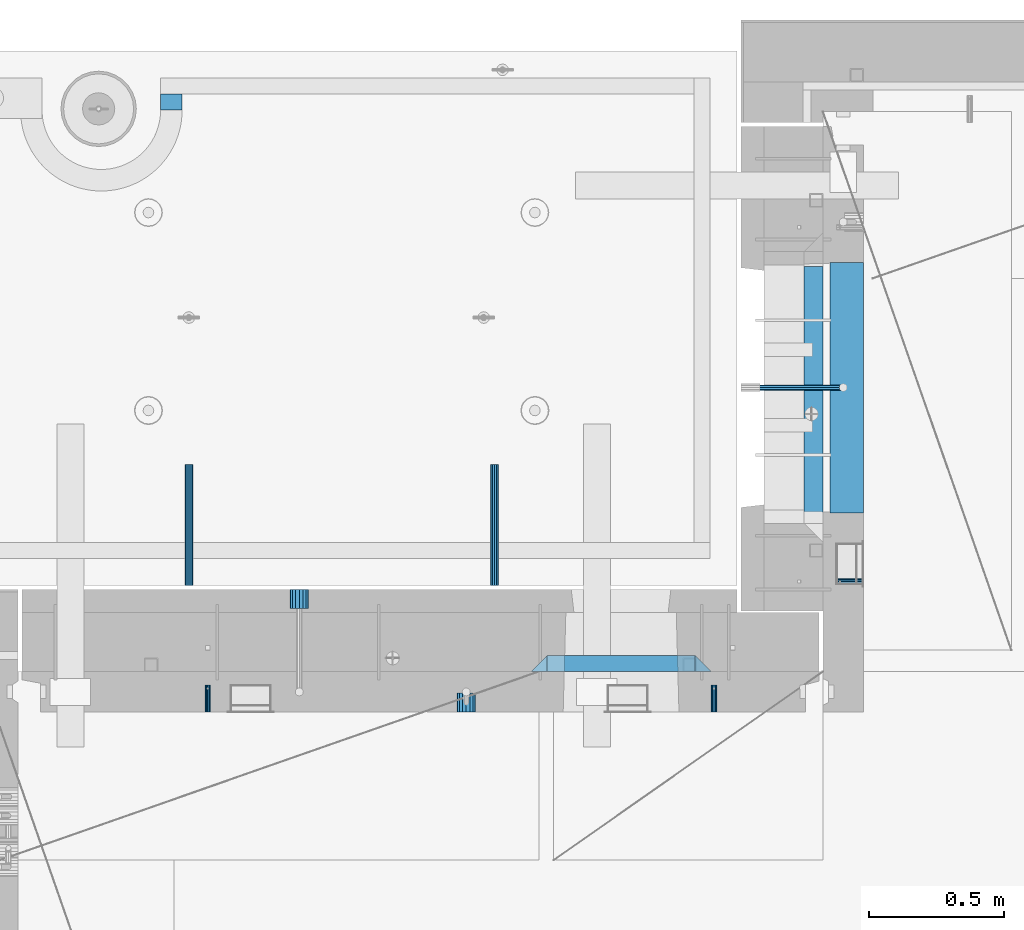
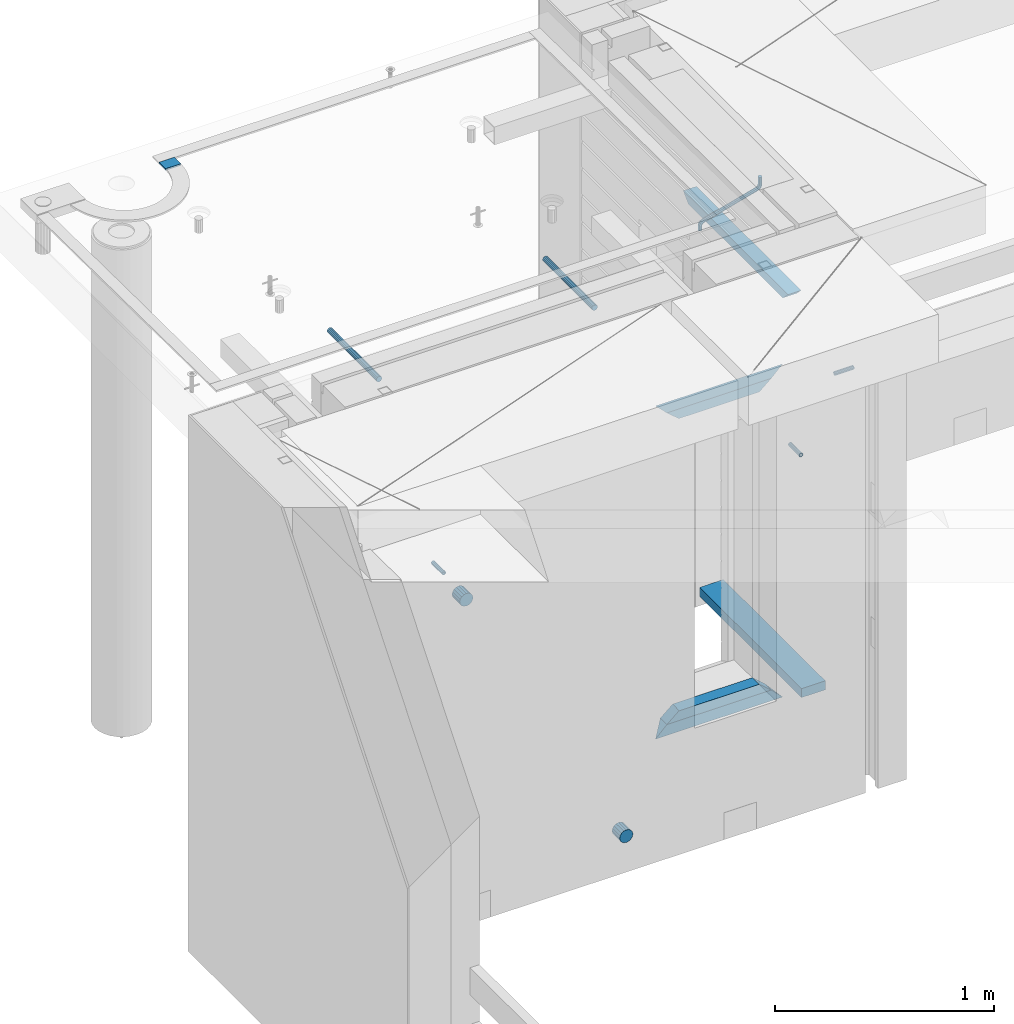
# One storey, part 150 of 334: 15 beams, 8 elements without a shape of their own.
"""IFC2X3 building model written with IfcOpenShell, lengths in millimetres."""

from ifc_helpers import new_model, si_unit, frame, origin_with_axes, place, context, subcontext, project, spatial, faceted_brep, material, type_object, element, aggregate, save


model = new_model("IFC2X3")

# Units and contexts
model_context = context("Model", 3, precision=1e-05, world=origin_with_axes())
body_context = subcontext(model_context, "Body", "Model", "MODEL_VIEW")
ifc_project = project(units=[si_unit("LENGTHUNIT", "METRE", prefix="MILLI"), si_unit("AREAUNIT", "SQUARE_METRE"), si_unit("VOLUMEUNIT", "CUBIC_METRE"), si_unit("MASSUNIT", "GRAM", prefix="KILO"), si_unit("TIMEUNIT", "SECOND"), si_unit("PLANEANGLEUNIT", "RADIAN"), si_unit("SOLIDANGLEUNIT", "STERADIAN"), si_unit("THERMODYNAMICTEMPERATUREUNIT", "DEGREE_CELSIUS"), si_unit("LUMINOUSINTENSITYUNIT", "LUMEN")], contexts=[model_context])

# Site, building, storey
site_placement = place(None, origin_with_axes())
site = spatial("IfcSite", under=ifc_project, at=site_placement, CompositionType="ELEMENT")
building_placement = place(site_placement, origin_with_axes())
building = spatial("IfcBuilding", under=site, at=building_placement, CompositionType="ELEMENT")
storey_placement = place(building_placement, origin_with_axes())
storey = spatial("IfcBuildingStorey", under=building, at=storey_placement, Name="3", CompositionType="ELEMENT", Elevation=0.0)

# Assembly, beam
assembly_1_placement = place(storey_placement, origin_with_axes())
assembly_1 = element("IfcElementAssembly", 1, at=assembly_1_placement, inside=storey, AssemblyPlace="NOTDEFINED", PredefinedType="REINFORCEMENT_UNIT")
ifc_material_1 = material(Name="CONCRETE/C25/30")
beam_type_1 = type_object("IfcBeamType", PredefinedType="NOTDEFINED")
beam_1_placement = place(assembly_1_placement, frame((10955.0, 22139.9998901814, 90080.0), z_axis=(0.0, 0.0, -1.0), x_axis=(0.0, -1.0, 0.0)))
beam_1 = element("IfcBeam", 2, at=beam_1_placement, type_object=beam_type_1, material=ifc_material_1, Name="SK", context=body_context, shape_type="Brep", body=[
    faceted_brep([(100.641025641038, 35.0, 20.6410256410309), (55.0, 35.0, -25.0), (55.0, -35.0, -25.0), (98.8461538461561, -35.0, 18.8461538461561), (966.153464684117, -35.0, 18.8461538461561), (964.358592889246, 35.0, 20.6410256410309), (1009.99961853027, 35.0, -25.0), (1009.99961853027, -35.0, -25.0)], [[[0, 1, 2, 3]], [[0, 3, 4, 5]], [[1, 0, 5, 6]], [[2, 1, 6, 7]], [[3, 2, 7, 4]], [[4, 7, 6, 5]]]),
])

# Assemblies, beams
assembly_2_placement = place(storey_placement, origin_with_axes())
assembly_2 = element("IfcElementAssembly", 3, at=assembly_2_placement, inside=storey, AssemblyPlace="NOTDEFINED", PredefinedType="REINFORCEMENT_UNIT")
assembly_3_placement = place(assembly_2_placement, origin_with_axes())
assembly_3 = element("IfcElementAssembly", 4, at=assembly_3_placement, Name="Steel Assembly", AssemblyPlace="NOTDEFINED", PredefinedType="RIGID_FRAME")
ifc_material_2 = material(Name="STEEL/Steel_Undefined")
beam_type_2 = type_object("IfcBeamType", PredefinedType="NOTDEFINED")
beam_2_placement = place(assembly_3_placement, frame((8704.99903261663, 20429.9951872276, 89755.0), z_axis=(1.0, 0.0, 0.0), x_axis=(0.0, 1.0, 0.0)))
beam_2 = element("IfcBeam", 5, at=beam_2_placement, type_object=beam_type_2, material=ifc_material_2, Name="M16", context=body_context, shape_type="Brep", body=[
    faceted_brep([(0.0, -8.49999999999272, -1.45519152283669e-11), (0.0, -7.36121593215648, 4.24999999998545), (100.000000000262, -7.36121593215648, 4.24999999998545), (100.000000000262, -8.49999999999272, -1.45519152283669e-11), (0.0, -4.24999999998545, 7.36121593216376), (100.000000000262, -4.24999999998545, 7.36121593216376), (0.0, 1.45519152283669e-11, 8.49999999998545), (100.000000000262, 1.45519152283669e-11, 8.49999999998545), (0.0, 4.25000000001455, 7.36121593216376), (100.000000000262, 4.25000000001455, 7.36121593216376), (0.0, 7.36121593217104, 4.24999999998545), (100.000000000262, 7.36121593217104, 4.24999999998545), (0.0, 8.50000000000728, 0.0), (100.000000000262, 8.50000000000728, 0.0), (0.0, 7.36121593217104, -4.25000000001455), (100.000000000262, 7.36121593217104, -4.25000000001455), (0.0, 4.25000000000728, -7.36121593219286), (100.000000000262, 4.25000000000728, -7.36121593219286), (0.0, 7.27595761418343e-12, -8.5), (100.000000000262, 7.27595761418343e-12, -8.5), (0.0, -4.24999999999272, -7.36121593217831), (100.000000000262, -4.24999999999272, -7.36121593217831), (0.0, -7.36121593215648, -4.25), (100.000000000262, -7.36121593215648, -4.25), (0.0, -10.4999999999927, -1.45519152283669e-11), (0.0, -9.09326673972828, -5.25000000001455), (100.000000000262, -9.09326673972828, -5.25000000001455), (100.000000000262, -10.4999999999927, -1.45519152283669e-11), (0.0, -5.24999999998545, -9.09326673974283), (100.000000000262, -5.24999999998545, -9.09326673974283), (0.0, 7.27595761418343e-12, -10.5), (100.000000000262, 7.27595761418343e-12, -10.5), (0.0, 5.25000000001455, -9.09326673975738), (100.000000000262, 5.25000000001455, -9.09326673975738), (0.0, 9.09326673975011, -5.25000000001455), (100.000000000262, 9.09326673975011, -5.25000000001455), (0.0, 10.5000000000073, -1.45519152283669e-11), (100.000000000262, 10.5000000000073, -1.45519152283669e-11), (0.0, 9.09326673975011, 5.25), (100.000000000262, 9.09326673975011, 5.25), (0.0, 5.25000000000728, 9.09326673972828), (100.000000000262, 5.25000000000728, 9.09326673972828), (0.0, 1.45519152283669e-11, 10.4999999999854), (100.000000000262, 1.45519152283669e-11, 10.4999999999854), (0.0, -5.24999999999272, 9.09326673972828), (100.000000000262, -5.24999999999272, 9.09326673972828), (0.0, -9.09326673972828, 5.24999999998545), (100.000000000262, -9.09326673972828, 5.24999999998545)], [[[0, 1, 2, 3]], [[1, 4, 5, 2]], [[4, 6, 7, 5]], [[6, 8, 9, 7]], [[8, 10, 11, 9]], [[10, 12, 13, 11]], [[12, 14, 15, 13]], [[14, 16, 17, 15]], [[16, 18, 19, 17]], [[18, 20, 21, 19]], [[20, 22, 23, 21]], [[22, 0, 3, 23]], [[24, 25, 26, 27]], [[25, 28, 29, 26]], [[28, 30, 31, 29]], [[30, 32, 33, 31]], [[32, 34, 35, 33]], [[34, 36, 37, 35]], [[36, 38, 39, 37]], [[38, 40, 41, 39]], [[40, 42, 43, 41]], [[42, 44, 45, 43]], [[44, 46, 47, 45]], [[46, 24, 27, 47]], [[29, 31, 33, 35, 37, 39, 41, 43, 45, 47, 27, 26], [5, 7, 9, 11, 13, 15, 17, 19, 21, 23, 3, 2]], [[46, 44, 42, 40, 38, 36, 34, 32, 30, 28, 25, 24], [22, 20, 18, 16, 14, 12, 10, 8, 6, 4, 1, 0]]]),
])
aggregate(assembly_3, [beam_2])
assembly_4_placement = place(assembly_2_placement, origin_with_axes())
assembly_4 = element("IfcElementAssembly", 6, at=assembly_4_placement, Name="Steel Assembly", AssemblyPlace="NOTDEFINED", PredefinedType="RIGID_FRAME")
beam_3_placement = place(assembly_4_placement, frame((10584.9990326166, 20429.9951872276, 89755.0), z_axis=(1.0, 0.0, 0.0), x_axis=(0.0, 1.0, 0.0)))
beam_3 = element("IfcBeam", 7, at=beam_3_placement, type_object=beam_type_2, material=ifc_material_2, Name="M16", context=body_context, shape_type="Brep", body=[
    faceted_brep([(0.0, -8.49999999999272, -1.45519152283669e-11), (0.0, -7.36121593215648, 4.24999999998545), (100.000000000262, -7.36121593215648, 4.24999999998545), (100.000000000262, -8.49999999999272, -1.45519152283669e-11), (0.0, -4.24999999998545, 7.36121593216376), (100.000000000262, -4.24999999998545, 7.36121593216376), (0.0, 1.45519152283669e-11, 8.49999999998545), (100.000000000262, 1.45519152283669e-11, 8.49999999998545), (0.0, 4.25000000001455, 7.36121593216376), (100.000000000262, 4.25000000001455, 7.36121593216376), (0.0, 7.36121593217104, 4.24999999998545), (100.000000000262, 7.36121593217104, 4.24999999998545), (0.0, 8.50000000000728, 0.0), (100.000000000262, 8.50000000000728, 0.0), (0.0, 7.36121593217104, -4.25000000001455), (100.000000000262, 7.36121593217104, -4.25000000001455), (0.0, 4.25000000000728, -7.36121593219286), (100.000000000262, 4.25000000000728, -7.36121593219286), (0.0, 7.27595761418343e-12, -8.5), (100.000000000262, 7.27595761418343e-12, -8.5), (0.0, -4.24999999999272, -7.36121593217831), (100.000000000262, -4.24999999999272, -7.36121593217831), (0.0, -7.36121593215648, -4.25), (100.000000000262, -7.36121593215648, -4.25), (0.0, -10.4999999999927, -1.45519152283669e-11), (0.0, -9.09326673972828, -5.25000000001455), (100.000000000262, -9.09326673972828, -5.25000000001455), (100.000000000262, -10.4999999999927, -1.45519152283669e-11), (0.0, -5.24999999998545, -9.09326673974283), (100.000000000262, -5.24999999998545, -9.09326673974283), (0.0, 7.27595761418343e-12, -10.5), (100.000000000262, 7.27595761418343e-12, -10.5), (0.0, 5.25000000001455, -9.09326673975738), (100.000000000262, 5.25000000001455, -9.09326673975738), (0.0, 9.09326673975011, -5.25000000001455), (100.000000000262, 9.09326673975011, -5.25000000001455), (0.0, 10.5000000000073, -1.45519152283669e-11), (100.000000000262, 10.5000000000073, -1.45519152283669e-11), (0.0, 9.09326673975011, 5.25), (100.000000000262, 9.09326673975011, 5.25), (0.0, 5.25000000000728, 9.09326673972828), (100.000000000262, 5.25000000000728, 9.09326673972828), (0.0, 1.45519152283669e-11, 10.4999999999854), (100.000000000262, 1.45519152283669e-11, 10.4999999999854), (0.0, -5.24999999999272, 9.09326673972828), (100.000000000262, -5.24999999999272, 9.09326673972828), (0.0, -9.09326673972828, 5.24999999998545), (100.000000000262, -9.09326673972828, 5.24999999998545)], [[[0, 1, 2, 3]], [[1, 4, 5, 2]], [[4, 6, 7, 5]], [[6, 8, 9, 7]], [[8, 10, 11, 9]], [[10, 12, 13, 11]], [[12, 14, 15, 13]], [[14, 16, 17, 15]], [[16, 18, 19, 17]], [[18, 20, 21, 19]], [[20, 22, 23, 21]], [[22, 0, 3, 23]], [[24, 25, 26, 27]], [[25, 28, 29, 26]], [[28, 30, 31, 29]], [[30, 32, 33, 31]], [[32, 34, 35, 33]], [[34, 36, 37, 35]], [[36, 38, 39, 37]], [[38, 40, 41, 39]], [[40, 42, 43, 41]], [[42, 44, 45, 43]], [[44, 46, 47, 45]], [[46, 24, 27, 47]], [[29, 31, 33, 35, 37, 39, 41, 43, 45, 47, 27, 26], [5, 7, 9, 11, 13, 15, 17, 19, 21, 23, 3, 2]], [[46, 44, 42, 40, 38, 36, 34, 32, 30, 28, 25, 24], [22, 20, 18, 16, 14, 12, 10, 8, 6, 4, 1, 0]]]),
])
aggregate(assembly_4, [beam_3])

# Assembly, beam
assembly_5_placement = place(assembly_1_placement, origin_with_axes())
assembly_5 = element("IfcElementAssembly", 8, at=assembly_5_placement, Name="Steel Assembly", AssemblyPlace="NOTDEFINED", PredefinedType="RIGID_FRAME")
beam_4_placement = place(assembly_5_placement, frame((11140.0, 20914.9954408996, 89755.0), z_axis=(0.0, -1.0, 0.0), x_axis=(-1.0, 3.00000001838171e-08, 0.0)))
beam_4 = element("IfcBeam", 9, at=beam_4_placement, type_object=beam_type_2, material=ifc_material_2, Name="M16", context=body_context, shape_type="Brep", body=[
    faceted_brep([(0.0, -8.49999999999272, -1.45519152283669e-11), (0.0, -7.36121593215648, 4.24999999998545), (100.000000000262, -7.36121593215648, 4.24999999998545), (100.000000000262, -8.49999999999272, -1.45519152283669e-11), (0.0, -4.24999999998545, 7.36121593216376), (100.000000000262, -4.24999999998545, 7.36121593216376), (0.0, 1.45519152283669e-11, 8.49999999998545), (100.000000000262, 1.45519152283669e-11, 8.49999999998545), (0.0, 4.25000000001455, 7.36121593216376), (100.000000000262, 4.25000000001455, 7.36121593216376), (0.0, 7.36121593217104, 4.24999999998545), (100.000000000262, 7.36121593217104, 4.24999999998545), (0.0, 8.50000000000728, 0.0), (100.000000000262, 8.50000000000728, 0.0), (0.0, 7.36121593217104, -4.25000000001455), (100.000000000262, 7.36121593217104, -4.25000000001455), (0.0, 4.25000000000728, -7.36121593219286), (100.000000000262, 4.25000000000728, -7.36121593219286), (0.0, 7.27595761418343e-12, -8.5), (100.000000000262, 7.27595761418343e-12, -8.5), (0.0, -4.24999999999272, -7.36121593217831), (100.000000000262, -4.24999999999272, -7.36121593217831), (0.0, -7.36121593215648, -4.25), (100.000000000262, -7.36121593215648, -4.25), (0.0, -10.4999999999927, -1.45519152283669e-11), (0.0, -9.09326673972828, -5.25000000001455), (100.000000000262, -9.09326673972828, -5.25000000001455), (100.000000000262, -10.4999999999927, -1.45519152283669e-11), (0.0, -5.24999999998545, -9.09326673974283), (100.000000000262, -5.24999999998545, -9.09326673974283), (0.0, 7.27595761418343e-12, -10.5), (100.000000000262, 7.27595761418343e-12, -10.5), (0.0, 5.25000000001455, -9.09326673975738), (100.000000000262, 5.25000000001455, -9.09326673975738), (0.0, 9.09326673975011, -5.25000000001455), (100.000000000262, 9.09326673975011, -5.25000000001455), (0.0, 10.5000000000073, -1.45519152283669e-11), (100.000000000262, 10.5000000000073, -1.45519152283669e-11), (0.0, 9.09326673975011, 5.25), (100.000000000262, 9.09326673975011, 5.25), (0.0, 5.25000000000728, 9.09326673972828), (100.000000000262, 5.25000000000728, 9.09326673972828), (0.0, 1.45519152283669e-11, 10.4999999999854), (100.000000000262, 1.45519152283669e-11, 10.4999999999854), (0.0, -5.24999999999272, 9.09326673972828), (100.000000000262, -5.24999999999272, 9.09326673972828), (0.0, -9.09326673972828, 5.24999999998545), (100.000000000262, -9.09326673972828, 5.24999999998545)], [[[0, 1, 2, 3]], [[1, 4, 5, 2]], [[4, 6, 7, 5]], [[6, 8, 9, 7]], [[8, 10, 11, 9]], [[10, 12, 13, 11]], [[12, 14, 15, 13]], [[14, 16, 17, 15]], [[16, 18, 19, 17]], [[18, 20, 21, 19]], [[20, 22, 23, 21]], [[22, 0, 3, 23]], [[24, 25, 26, 27]], [[25, 28, 29, 26]], [[28, 30, 31, 29]], [[30, 32, 33, 31]], [[32, 34, 35, 33]], [[34, 36, 37, 35]], [[36, 38, 39, 37]], [[38, 40, 41, 39]], [[40, 42, 43, 41]], [[42, 44, 45, 43]], [[44, 46, 47, 45]], [[46, 24, 27, 47]], [[29, 31, 33, 35, 37, 39, 41, 43, 45, 47, 27, 26], [5, 7, 9, 11, 13, 15, 17, 19, 21, 23, 3, 2]], [[46, 44, 42, 40, 38, 36, 34, 32, 30, 28, 25, 24], [22, 20, 18, 16, 14, 12, 10, 8, 6, 4, 1, 0]]]),
])
aggregate(assembly_5, [beam_4])

# Beam
ifc_material_3 = material()
beam_type_3 = type_object("IfcBeamType", Name="D20", PredefinedType="NOTDEFINED")
beam_5_placement = place(assembly_1_placement, frame((10747.93, 21634.9982799665, 90220.28), z_axis=(0.999209485784166, 0.00020572799995638, -0.0397537569914116), x_axis=(0.0397537569984931, -6.39999925638531e-08, 0.999209506962629)))
beam_5 = element("IfcBeam", 10, at=beam_5_placement, type_object=beam_type_3, material=ifc_material_3, Name="JM20", ObjectType="D20", context=body_context, shape_type="Brep", body=[
    faceted_brep([(0.0, -10.0, 0.0), (-4.19531716033816e-08, -7.07106781186667, -7.07106781187031), (26.3851730625611, -7.07106780271351, -7.07106779974674), (26.3851730660535, -9.99999999077045, 1.18243406177498e-08), (0.0, 0.0, -10.0), (26.3851730589668, 9.14587872102857e-09, -9.99999998788189), (4.196772351861e-08, 7.07106781186303, -7.07106781186667), (26.3851730576571, 7.07106782101255, -7.0710677997472), (0.0, 10.0, 0.0), (26.3851730593888, 10.0000000091495, 1.21176526590716e-08), (4.196772351861e-08, 7.07106781185939, 7.07106781185939), (26.3851730631723, 7.07106782101619, 7.07106782398387), (0.0, 0.0, 10.0), (26.3851730667375, 9.15315467864275e-09, 10.0000000121181), (-4.19531716033816e-08, -7.07106781187031, 7.07106781185939), (26.3851730680617, -7.07106780271351, 7.07106782398296), (38.6387990555377, 0.00053833780111745, -7.38336449283906), (37.4430586178205, -7.07058200552274, -4.70977034770021), (34.5550974405633, -9.99964106806146, 1.74460312923975), (31.6666440137633, -7.07083577596131, 8.19887149183023), (30.4697151806322, 0.000179452214069897, 10.8722118684241), (31.6654556183639, 7.07129979554884, 8.19861772327886), (34.5534167956066, 10.0003588580803, 1.74424424634026), (37.4418702223775, 7.07155356597286, -4.71002411625204), (46.5698109210789, 7.07292605872499, 1.96124086770624), (48.7548734831362, 0.00205940803425619, 0.0100898832683924), (41.2967727296491, 10.0013728005906, 6.67270684289633), (36.0246331664675, 7.07195524891722, 11.3845749391899), (33.8417400848848, 0.000686475628754124, 13.3366967298962), (36.0268026468402, -7.07018017507653, 11.385545745416), (41.2998408382991, -9.99862691692761, 6.67407977023777), (46.5719804015243, -7.06920936526149, 1.96221167398289), (52.1766955363273, 7.07494587836845, 11.77897587077), (54.9687243336812, 0.00429788071051007, 10.8906314292522), (45.4389138642146, 10.0028649622, 13.9256551011317), (38.7022804405424, 7.07291984242329, 16.0731735411446), (35.9130237601494, 0.00143263318750542, 16.9635440140905), (38.7050525575032, -7.06921536447044, 16.0751995724927), (45.4428342298197, -9.99713444846202, 13.9285203429881), (52.1794676532882, -7.06718932852891, 11.7810019021831), (142.166420299589, -7.00909836739083, 294.143799597011), (135.429786872017, -9.93904348683645, 296.291318034092), (144.955676979953, 0.0623888418631395, 293.253429124143), (142.163648182657, 7.13303683951744, 294.141773565681), (135.425866510661, 10.0609559233271, 296.288452795829), (128.689233087061, 7.13101080351771, 298.435971235634), (125.899976406712, 0.0595235942673753, 299.326341708503), (128.692005203993, -7.01112440339057, 298.437997266966), (147.068569920637, 0.0631443010061048, 296.926548661886), (144.897857494318, -7.00812174957537, 298.892215917644), (139.655137467547, -9.93753272500544, 303.636800386314), (134.411524128242, -7.00907940566321, 308.380988833921), (132.238655054738, 0.0617899707685865, 310.345700010335), (134.409367481101, 7.13305602133914, 308.38003275464), (139.652087507944, 10.0624669967765, 303.63544828606), (144.895700847192, 7.13401367743427, 298.891259838389), (149.349355837621, 7.13466950711154, 302.082919188319), (150.512901837996, 0.0636515012993186, 299.394888529177), (146.541460642286, 10.0634815017911, 308.572636332), (143.734043175544, 7.13442914049301, 315.062451673432), (142.571650514263, 0.0633115715718304, 317.750719402909), (143.735196514695, -7.0077064342513, 315.062688743805), (146.543091710148, -9.93651842893087, 308.572971600169), (149.350509176773, -7.0074660676255, 302.083156258706), (154.724909358454, 7.13488656737172, 303.143653317829), (154.670204234542, 0.063819369621342, 300.215230568659), (154.856921558763, 10.0638172729959, 310.213489346082), (154.988909878753, 7.13488360238989, 317.283324591871), (155.043557350815, 0.0638151764978829, 320.211745451903), (154.988852227005, -7.00725202125614, 317.28332270274), (154.856840031658, -9.93618272723688, 310.213486674455), (154.724851706691, -7.00724905626703, 303.143651428684), (199.544700311235, -7.00743165723543, 302.30682413155), (199.676688632229, -9.93636532781238, 309.37665937721), (199.490052838737, 0.0636367686238373, 299.378403271518), (199.544757962984, 7.13470396637786, 302.306826020583), (199.676770164122, 10.0636346720203, 309.376662048705), (199.808758485131, 7.13470100144696, 316.446497294365), (199.863405957614, 0.0636325755804137, 319.374918154397), (199.808700833368, -7.00743462216269, 316.446495405334)], [[[0, 1, 2, 3]], [[1, 4, 5, 2]], [[4, 6, 7, 5]], [[6, 8, 9, 7]], [[8, 10, 11, 9]], [[10, 12, 13, 11]], [[12, 14, 15, 13]], [[14, 0, 3, 15]], [[14, 12, 10, 8, 6, 4, 1, 0]], [[2, 5, 16, 17]], [[3, 2, 17, 18]], [[15, 3, 18, 19]], [[13, 15, 19, 20]], [[11, 13, 20, 21]], [[9, 11, 21, 22]], [[7, 9, 22, 23]], [[5, 7, 23, 16]], [[23, 24, 25, 16]], [[22, 26, 24, 23]], [[21, 27, 26, 22]], [[20, 28, 27, 21]], [[19, 29, 28, 20]], [[18, 30, 29, 19]], [[17, 31, 30, 18]], [[16, 25, 31, 17]], [[24, 32, 33, 25]], [[26, 34, 32, 24]], [[27, 35, 34, 26]], [[28, 36, 35, 27]], [[29, 37, 36, 28]], [[30, 38, 37, 29]], [[31, 39, 38, 30]], [[25, 33, 39, 31]], [[38, 39, 40, 41]], [[39, 33, 42, 40]], [[33, 32, 43, 42]], [[32, 34, 44, 43]], [[34, 35, 45, 44]], [[35, 36, 46, 45]], [[36, 37, 47, 46]], [[37, 38, 41, 47]], [[40, 42, 48, 49]], [[41, 40, 49, 50]], [[47, 41, 50, 51]], [[46, 47, 51, 52]], [[45, 46, 52, 53]], [[44, 45, 53, 54]], [[43, 44, 54, 55]], [[42, 43, 55, 48]], [[55, 56, 57, 48]], [[54, 58, 56, 55]], [[53, 59, 58, 54]], [[52, 60, 59, 53]], [[51, 61, 60, 52]], [[50, 62, 61, 51]], [[49, 63, 62, 50]], [[48, 57, 63, 49]], [[56, 64, 65, 57]], [[58, 66, 64, 56]], [[59, 67, 66, 58]], [[60, 68, 67, 59]], [[61, 69, 68, 60]], [[62, 70, 69, 61]], [[63, 71, 70, 62]], [[57, 65, 71, 63]], [[70, 71, 72, 73]], [[71, 65, 74, 72]], [[65, 64, 75, 74]], [[64, 66, 76, 75]], [[66, 67, 77, 76]], [[67, 68, 78, 77]], [[68, 69, 79, 78]], [[69, 70, 73, 79]], [[74, 75, 76, 77, 78, 79, 73, 72]]]),
])

beam_type_4 = type_object("IfcBeamType", Name="D70", PredefinedType="NOTDEFINED")
beam_6_placement = place(assembly_2_placement, frame((9665.00172002957, 20429.9951872276, 87955.0), z_axis=(0.0, 0.0, 1.0), x_axis=(0.0, 1.0, 0.0)))
beam_6 = element("IfcBeam", 11, at=beam_6_placement, type_object=beam_type_4, material=ifc_material_3, ObjectType="D70", context=body_context, shape_type="Brep", body=[
    faceted_brep([(0.0, -35.0, 0.0), (0.0, -32.3357836378964, -13.3939201327739), (70.0, -32.3357836378964, -13.3939201327739), (70.0, -35.0, 0.0), (0.0, -24.7487373415279, -24.7487373415352), (70.0, -24.7487373415279, -24.7487373415352), (0.0, -13.3939201327776, -32.3357836379), (70.0, -13.3939201327776, -32.3357836379), (0.0, 0.0, -35.0), (70.0, 0.0, -35.0), (0.0, 13.3939201327776, -32.3357836379), (70.0, 13.3939201327776, -32.3357836379), (0.0, 24.7487373415279, -24.7487373415352), (70.0, 24.7487373415279, -24.7487373415352), (0.0, 32.3357836378964, -13.3939201327739), (70.0, 32.3357836378964, -13.3939201327739), (0.0, 35.0, 0.0), (70.0, 35.0, 0.0), (0.0, 32.3357836378964, 13.3939201327739), (70.0, 32.3357836378964, 13.3939201327739), (0.0, 24.7487373415279, 24.7487373415352), (70.0, 24.7487373415279, 24.7487373415352), (0.0, 13.3939201327776, 32.3357836379), (70.0, 13.3939201327776, 32.3357836379), (0.0, 0.0, 35.0), (70.0, 0.0, 35.0), (0.0, -13.3939201327776, 32.3357836379), (70.0, -13.3939201327776, 32.3357836379), (0.0, -24.7487373415279, 24.7487373415352), (70.0, -24.7487373415279, 24.7487373415352), (0.0, -32.3357836378964, 13.3939201327739), (70.0, -32.3357836378964, 13.3939201327739)], [[[0, 1, 2, 3]], [[1, 4, 5, 2]], [[4, 6, 7, 5]], [[6, 8, 9, 7]], [[8, 10, 11, 9]], [[10, 12, 13, 11]], [[12, 14, 15, 13]], [[14, 16, 17, 15]], [[16, 18, 19, 17]], [[18, 20, 21, 19]], [[20, 22, 23, 21]], [[22, 24, 25, 23]], [[24, 26, 27, 25]], [[26, 28, 29, 27]], [[28, 30, 31, 29]], [[30, 0, 3, 31]], [[5, 7, 9, 11, 13, 15, 17, 19, 21, 23, 25, 27, 29, 31, 3, 2]], [[30, 28, 26, 24, 22, 20, 18, 16, 14, 12, 10, 8, 6, 4, 1, 0]]]),
])

beam_7_placement = place(assembly_2_placement, frame((9044.99633327303, 20884.9951872276, 89255.0), z_axis=(0.0, 0.0, 1.0), x_axis=(0.0, -1.0, 0.0)))
beam_7 = element("IfcBeam", 12, at=beam_7_placement, type_object=beam_type_4, material=ifc_material_3, ObjectType="D70", context=body_context, shape_type="Brep", body=[
    faceted_brep([(0.0, -35.0, 0.0), (0.0, -32.3357836378964, -13.3939201327739), (70.0, -32.3357836378964, -13.3939201327739), (70.0, -35.0, 0.0), (0.0, -24.7487373415279, -24.7487373415352), (70.0, -24.7487373415279, -24.7487373415352), (0.0, -13.3939201327776, -32.3357836379), (70.0, -13.3939201327776, -32.3357836379), (0.0, 0.0, -35.0), (70.0, 0.0, -35.0), (0.0, 13.3939201327776, -32.3357836379), (70.0, 13.3939201327776, -32.3357836379), (0.0, 24.7487373415279, -24.7487373415352), (70.0, 24.7487373415279, -24.7487373415352), (0.0, 32.3357836378964, -13.3939201327739), (70.0, 32.3357836378964, -13.3939201327739), (0.0, 35.0, 0.0), (70.0, 35.0, 0.0), (0.0, 32.3357836378964, 13.3939201327739), (70.0, 32.3357836378964, 13.3939201327739), (0.0, 24.7487373415279, 24.7487373415352), (70.0, 24.7487373415279, 24.7487373415352), (0.0, 13.3939201327776, 32.3357836379), (70.0, 13.3939201327776, 32.3357836379), (0.0, 0.0, 35.0), (70.0, 0.0, 35.0), (0.0, -13.3939201327776, 32.3357836379), (70.0, -13.3939201327776, 32.3357836379), (0.0, -24.7487373415279, 24.7487373415352), (70.0, -24.7487373415279, 24.7487373415352), (0.0, -32.3357836378964, 13.3939201327739), (70.0, -32.3357836378964, 13.3939201327739)], [[[0, 1, 2, 3]], [[1, 4, 5, 2]], [[4, 6, 7, 5]], [[6, 8, 9, 7]], [[8, 10, 11, 9]], [[10, 12, 13, 11]], [[12, 14, 15, 13]], [[14, 16, 17, 15]], [[16, 18, 19, 17]], [[18, 20, 21, 19]], [[20, 22, 23, 21]], [[22, 24, 25, 23]], [[24, 26, 27, 25]], [[26, 28, 29, 27]], [[28, 30, 31, 29]], [[30, 0, 3, 31]], [[5, 7, 9, 11, 13, 15, 17, 19, 21, 23, 25, 27, 29, 31, 3, 2]], [[30, 28, 26, 24, 22, 20, 18, 16, 14, 12, 10, 8, 6, 4, 1, 0]]]),
])

ifc_material_4 = material(Name="TIMBER/PUU")
beam_type_5 = type_object("IfcBeamType", PredefinedType="NOTDEFINED")
beam_8_placement = place(assembly_1_placement, frame((11077.5, 21169.9999618525, 87830.0), z_axis=(0.0, 0.0, 1.0), x_axis=(0.0, 1.0, 0.0)))
beam_8 = element("IfcBeam", 13, at=beam_8_placement, type_object=beam_type_5, material=ifc_material_4, context=body_context, shape_type="Brep", body=[
    faceted_brep([(0.0, 62.5, -25.0), (0.0, 62.5, 25.0), (930.0, 62.5, 25.0), (930.0, 62.5, -25.0), (0.0, -62.5, 25.0), (930.0, -62.5, 25.0), (0.0, -62.5, -25.0), (930.0, -62.5, -25.0)], [[[0, 1, 2, 3]], [[1, 4, 5, 2]], [[4, 6, 7, 5]], [[6, 0, 3, 7]], [[5, 7, 3, 2]], [[6, 4, 1, 0]]]),
])

aggregate(assembly_1, [beam_5, assembly_5, beam_8, beam_1])

# Assemblies, beams
assembly_6_placement = place(storey_placement, origin_with_axes())
assembly_6 = element("IfcElementAssembly", 14, at=assembly_6_placement, inside=storey, AssemblyPlace="NOTDEFINED", PredefinedType="REINFORCEMENT_UNIT")
assembly_7_placement = place(assembly_6_placement, origin_with_axes())
assembly_7 = element("IfcElementAssembly", 15, at=assembly_7_placement, Name="Steel Assembly", AssemblyPlace="NOTDEFINED", PredefinedType="RIGID_FRAME")
ifc_material_5 = material(Name="STEEL/S235JR")
beam_type_6 = type_object("IfcBeamType", Name="D30", PredefinedType="NOTDEFINED")
beam_9_placement = place(assembly_7_placement, frame((8634.99985675633, 20900.0253394533, 90575.0), z_axis=(0.0, 0.0, 1.0), x_axis=(0.0, 1.0, 0.0)))
beam_9 = element("IfcBeam", 16, at=beam_9_placement, type_object=beam_type_6, material=ifc_material_5, Name="Rd30", ObjectType="D30", context=body_context, shape_type="Brep", body=[
    faceted_brep([(0.0, -15.0, 0.0), (0.0, -12.9903810567666, -7.5), (450.0, -12.9903810567666, -7.5), (450.0, -15.0, 0.0), (0.0, -7.5, -12.9903810567666), (450.0, -7.5, -12.990381056763), (0.0, 0.0, -15.0), (450.0, 0.0, -15.0), (0.0, 7.5, -12.9903810567666), (450.0, 7.5, -12.990381056763), (0.0, 12.9903810567666, -7.5), (450.0, 12.9903810567666, -7.5), (0.0, 15.0, 0.0), (450.0, 15.0, 0.0), (0.0, 12.9903810567666, 7.5), (450.0, 12.9903810567666, 7.5), (0.0, 7.5, 12.9903810567666), (450.0, 7.5, 12.990381056763), (0.0, 0.0, 15.0), (450.0, 0.0, 15.0), (0.0, -7.5, 12.9903810567666), (450.0, -7.5, 12.990381056763), (0.0, -12.9903810567666, 7.5), (450.0, -12.9903810567666, 7.5)], [[[0, 1, 2, 3]], [[1, 4, 5, 2]], [[4, 6, 7, 5]], [[6, 8, 9, 7]], [[8, 10, 11, 9]], [[10, 12, 13, 11]], [[12, 14, 15, 13]], [[14, 16, 17, 15]], [[16, 18, 19, 17]], [[18, 20, 21, 19]], [[20, 22, 23, 21]], [[22, 0, 3, 23]], [[5, 7, 9, 11, 13, 15, 17, 19, 21, 23, 3, 2]], [[22, 20, 18, 16, 14, 12, 10, 8, 6, 4, 1, 0]]]),
])
aggregate(assembly_7, [beam_9])
assembly_8_placement = place(assembly_6_placement, origin_with_axes())
assembly_8 = element("IfcElementAssembly", 17, at=assembly_8_placement, Name="Steel Assembly", AssemblyPlace="NOTDEFINED", PredefinedType="RIGID_FRAME")
beam_10_placement = place(assembly_8_placement, frame((9769.99985700661, 20900.0152136098, 90575.0), z_axis=(0.0, 0.0, 1.0), x_axis=(0.0, 1.0, 0.0)))
beam_10 = element("IfcBeam", 18, at=beam_10_placement, type_object=beam_type_6, material=ifc_material_5, Name="Rd30", ObjectType="D30", context=body_context, shape_type="Brep", body=[
    faceted_brep([(0.0, -15.0, 0.0), (0.0, -12.9903810567666, -7.5), (450.0, -12.9903810567666, -7.5), (450.0, -15.0, 0.0), (0.0, -7.5, -12.9903810567666), (450.0, -7.5, -12.990381056763), (0.0, 0.0, -15.0), (450.0, 0.0, -15.0), (0.0, 7.5, -12.9903810567666), (450.0, 7.5, -12.990381056763), (0.0, 12.9903810567666, -7.5), (450.0, 12.9903810567666, -7.5), (0.0, 15.0, 0.0), (450.0, 15.0, 0.0), (0.0, 12.9903810567666, 7.5), (450.0, 12.9903810567666, 7.5), (0.0, 7.5, 12.9903810567666), (450.0, 7.5, 12.990381056763), (0.0, 0.0, 15.0), (450.0, 0.0, 15.0), (0.0, -7.5, 12.9903810567666), (450.0, -7.5, 12.990381056763), (0.0, -12.9903810567666, 7.5), (450.0, -12.9903810567666, 7.5)], [[[0, 1, 2, 3]], [[1, 4, 5, 2]], [[4, 6, 7, 5]], [[6, 8, 9, 7]], [[8, 10, 11, 9]], [[10, 12, 13, 11]], [[12, 14, 15, 13]], [[14, 16, 17, 15]], [[16, 18, 19, 17]], [[18, 20, 21, 19]], [[20, 22, 23, 21]], [[22, 0, 3, 23]], [[5, 7, 9, 11, 13, 15, 17, 19, 21, 23, 3, 2]], [[22, 20, 18, 16, 14, 12, 10, 8, 6, 4, 1, 0]]]),
])
aggregate(assembly_8, [beam_10])

# Beam
beam_type_7 = type_object("IfcBeamType", PredefinedType="NOTDEFINED")
beam_11_placement = place(assembly_2_placement, frame((10575.0002360344, 20609.9951872276, 90145.0), z_axis=(0.0, 0.0, -1.0), x_axis=(-1.0, 3.00000001838171e-08, 0.0)))
beam_11 = element("IfcBeam", 19, at=beam_11_placement, type_object=beam_type_7, material=ifc_material_1, Name="SK", context=body_context, shape_type="Brep", body=[
    faceted_brep([(60.0000000000073, 30.0, 30.0), (0.0, -30.0, -30.0), (60.0000000000073, -30.0, 30.0), (610.001525878895, 30.0, 30.0), (670.001525878906, -30.0, -30.0), (610.001525878895, -30.0, 30.0)], [[[0, 1, 2]], [[1, 0, 3, 4]], [[2, 1, 4, 5]], [[0, 2, 5, 3]], [[5, 4, 3]]]),
])

beam_12_placement = place(assembly_2_placement, frame((10515.0002360344, 20609.9951872276, 90085.0), z_axis=(0.0, 0.0, -1.0), x_axis=(-1.0, 3.00000001838171e-08, 0.0)))
beam_12 = element("IfcBeam", 20, at=beam_12_placement, type_object=beam_type_7, material=ifc_material_1, Name="SK", context=body_context, shape_type="Brep", body=[
    faceted_brep([(0.0, -30.0, -30.0), (64.0555799329595, -30.0, 24.9047827876493), (65.6772015545812, 30.0, 26.2947441772849), (0.0, 30.0, -30.0), (64.0555799329595, -30.0, 24.0540540540533), (65.6772015545812, 30.0, 25.6756756756804), (485.947471824853, -30.0, 24.0540540540533), (484.325850203231, 30.0, 25.6756756756804), (484.325850203231, 30.0, 26.293436281092), (550.001525878906, 30.0, -30.0), (550.001525878906, -30.0, -30.0), (485.947471824853, -30.0, 24.9034748914273)], [[[0, 1, 2, 3]], [[4, 5, 2, 1]], [[6, 7, 5, 4]], [[3, 2, 5, 7, 8, 9]], [[0, 3, 9, 10]], [[6, 4, 1, 0, 10, 11]], [[7, 6, 11, 8]], [[8, 11, 10, 9]]]),
])

beam_13_placement = place(assembly_2_placement, frame((9904.99871015549, 20609.9951872276, 88350.0), z_axis=(0.0, 0.0, 1.0), x_axis=(1.0, 0.0, 0.0)))
beam_13 = element("IfcBeam", 21, at=beam_13_placement, type_object=beam_type_7, material=ifc_material_1, Name="SK", context=body_context, shape_type="Brep", body=[
    faceted_brep([(610.001525878895, -30.0, 30.0), (670.001525878906, -30.0, -30.0), (610.001525878895, 30.0, 30.0), (60.0000000000073, 30.0, 30.0), (60.0000000000073, -30.0, 30.0), (0.0, -30.0, -30.0)], [[[0, 1, 2]], [[3, 4, 0, 2]], [[4, 5, 1, 0]], [[5, 3, 2, 1]], [[3, 5, 4]]]),
])

beam_14_placement = place(assembly_2_placement, frame((9964.99871015549, 20609.9951872276, 88410.0), z_axis=(0.0, 0.0, 1.0), x_axis=(1.0, 0.0, 0.0)))
beam_14 = element("IfcBeam", 22, at=beam_14_placement, type_object=beam_type_7, material=ifc_material_1, Name="SK", context=body_context, shape_type="Brep", body=[
    faceted_brep([(550.001525878906, -30.0, -30.0), (550.001525878906, 30.0, -30.0), (484.324324324325, 30.0, 26.2947441772849), (485.945945945947, -30.0, 24.9047827876348), (484.324324324325, 30.0, 25.6756756756804), (485.945945945947, -30.0, 24.0540540540533), (65.6756756756768, 30.0, 25.6756756756804), (64.0540540540533, -30.0, 24.0540540540533), (65.6756756756768, 30.0, 26.293436281092), (64.0540540540533, -30.0, 24.9034748914419), (0.0, -30.0, -30.0), (0.0, 30.0, -30.0)], [[[0, 1, 2, 3]], [[4, 5, 3, 2]], [[5, 4, 6, 7]], [[7, 6, 8, 9]], [[0, 3, 5, 7, 9, 10]], [[10, 11, 1, 0]], [[6, 4, 2, 1, 11, 8]], [[10, 9, 8, 11]]]),
])

aggregate(assembly_2, [assembly_3, assembly_4, beam_6, beam_7, beam_11, beam_12, beam_13, beam_14])

ifc_material_6 = material(Name="CONCRETE/Concrete_Undefined")
beam_type_8 = type_object("IfcBeamType", PredefinedType="NOTDEFINED")
beam_15_placement = place(assembly_6_placement, frame((8570.00544375128, 22665.0534145719, 90707.3590237257), z_axis=(1.00999999609277e-07, -0.00299573299934615, 0.999995512781826), x_axis=(-0.000187248000059734, 0.999995495250841, 0.0029957330006511)))
beam_15 = element("IfcBeam", 23, at=beam_15_placement, type_object=beam_type_8, material=ifc_material_6, context=body_context, shape_type="Brep", body=[
    faceted_brep([(1.34605215862393e-10, 40.0, -5.0), (-1.20053300634027e-10, 39.9999999999982, 4.99999999998545), (60.1825564420724, 39.9999999999982, 5.0), (60.182556442418, 40.0, -5.0), (-1.23691279441118e-10, -40.0000000000018, 4.9999999999709), (60.1825564420724, -40.0, 5.0), (1.30967237055302e-10, -40.0, -5.00000000001455), (60.182556442418, -39.9999999999982, -5.0)], [[[0, 1, 2, 3]], [[1, 4, 5, 2]], [[4, 6, 7, 5]], [[6, 0, 3, 7]], [[5, 7, 3, 2]], [[6, 4, 1, 0]]]),
])

aggregate(assembly_6, [beam_15, assembly_7, assembly_8])

save(model, "model.ifc")
